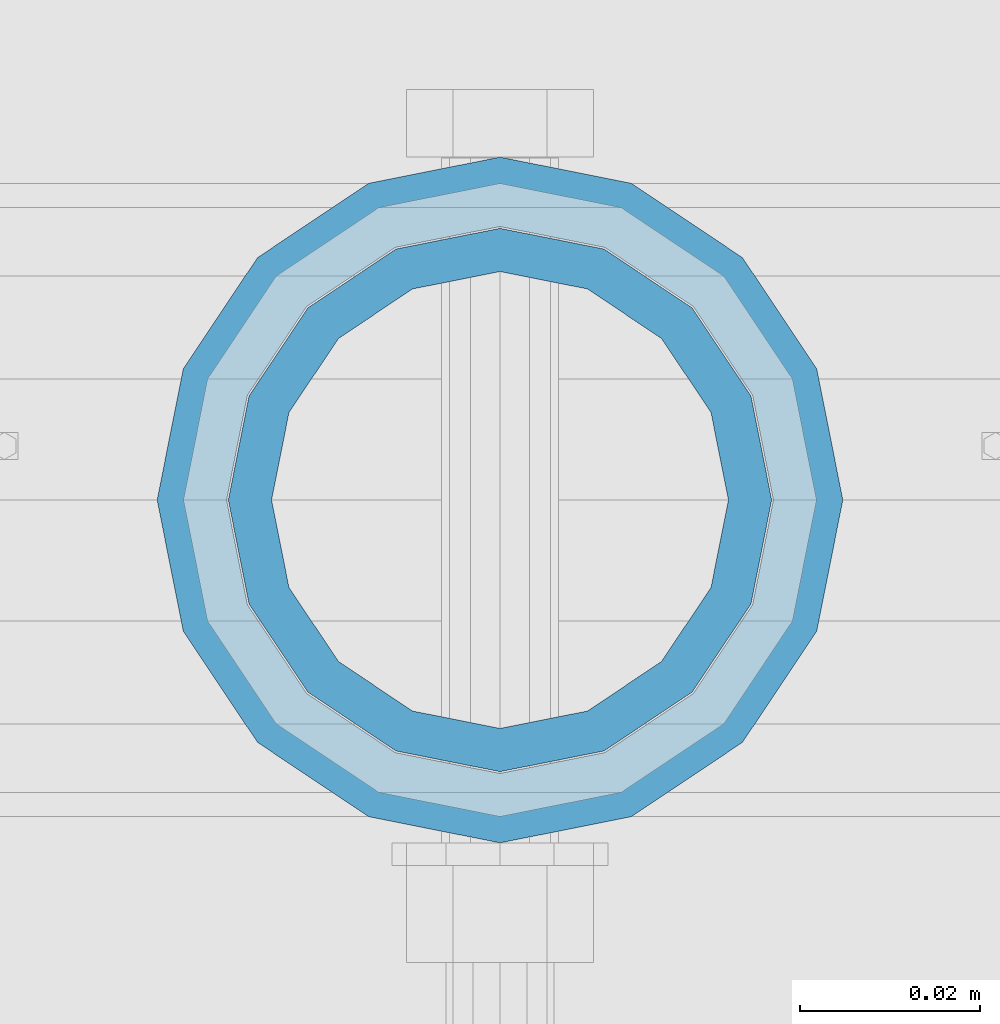
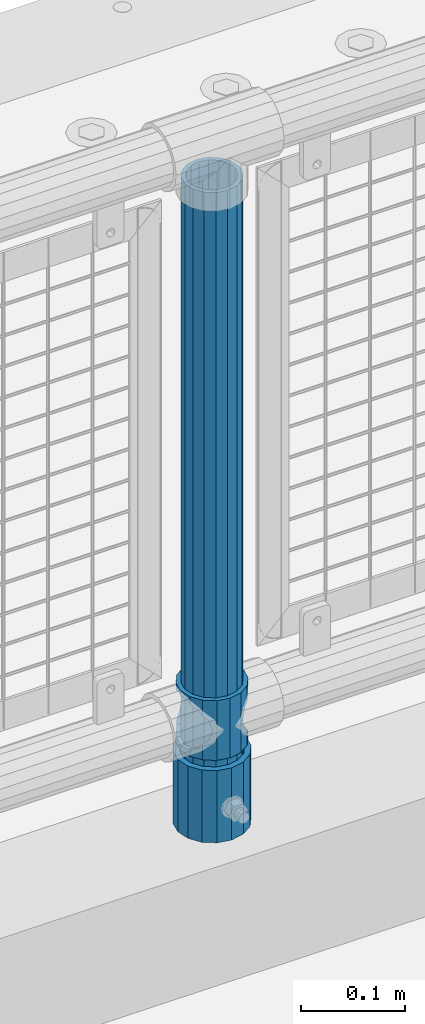
# One storey, part 71 of 247: 3 columns.
"""IFC2X3 building model written with IfcOpenShell, lengths in millimetres."""

from ifc_helpers import new_model, si_unit, frame, origin_with_axes, place, context, subcontext, project, spatial, faceted_brep, material, type_object, element, save


model = new_model("IFC2X3")

# Units and contexts
model_context = context("Model", 3, precision=1e-05, world=origin_with_axes())
body_context = subcontext(model_context, "Body", "Model", "MODEL_VIEW")
ifc_project = project(units=[si_unit("LENGTHUNIT", "METRE", prefix="MILLI"), si_unit("AREAUNIT", "SQUARE_METRE"), si_unit("VOLUMEUNIT", "CUBIC_METRE"), si_unit("MASSUNIT", "GRAM", prefix="KILO"), si_unit("TIMEUNIT", "SECOND"), si_unit("PLANEANGLEUNIT", "RADIAN"), si_unit("SOLIDANGLEUNIT", "STERADIAN"), si_unit("THERMODYNAMICTEMPERATUREUNIT", "DEGREE_CELSIUS"), si_unit("LUMINOUSINTENSITYUNIT", "LUMEN")], contexts=[model_context])

# Site, building, storey
site_placement = place(None, origin_with_axes())
site = spatial("IfcSite", under=ifc_project, at=site_placement, CompositionType="ELEMENT")
building_placement = place(site_placement, origin_with_axes())
building = spatial("IfcBuilding", under=site, at=building_placement, Name="Standard", CompositionType="ELEMENT")
storey_placement = place(building_placement, origin_with_axes())
storey = spatial("IfcBuildingStorey", under=building, at=storey_placement, Name="Undefined", CompositionType="ELEMENT", Elevation=0.0)

# Columns
ifc_material_1 = material()
column_type_1 = type_object("IfcColumnType", PredefinedType="NOTDEFINED")
column_1_placement = place(storey_placement, frame((2221.0, 7664.5, 168.02), z_axis=(0.0, 1.0, 0.0), x_axis=(0.0, 0.0, 1.0)))
element("IfcColumn", 1, at=column_1_placement, inside=storey, type_object=column_type_1, material=ifc_material_1, context=body_context, shape_type="Brep", body=[
    faceted_brep([(0.0, -31.75, 0.0), (0.0, -29.3331751572332, 12.1501989775916), (85.0, -29.3331751572332, 12.1501989775916), (85.0, -31.75, 0.0), (0.0, -22.4506403026735, 22.4506403026726), (85.0, -22.4506403026735, 22.4506403026726), (0.0, -12.1501989775916, 29.3331751572332), (85.0, -12.1501989775916, 29.3331751572332), (0.0, 0.0, 31.75), (85.0, 0.0, 31.75), (0.0, 12.1501989775916, 29.3331751572332), (85.0, 12.1501989775916, 29.3331751572332), (0.0, 22.4506403026735, 22.4506403026726), (85.0, 22.4506403026735, 22.4506403026726), (0.0, 29.3331751572332, 12.1501989775916), (85.0, 29.3331751572332, 12.1501989775916), (0.0, 31.75, 0.0), (85.0, 31.75, 0.0), (0.0, 29.3331751572332, -12.1501989775916), (85.0, 29.3331751572332, -12.1501989775916), (0.0, 22.4506403026735, -22.4506403026726), (85.0, 22.4506403026735, -22.4506403026726), (0.0, 12.1501989775916, -29.3331751572332), (85.0, 12.1501989775916, -29.3331751572332), (0.0, 0.0, -31.75), (85.0, 0.0, -31.75), (0.0, -12.1501989775916, -29.3331751572332), (85.0, -12.1501989775916, -29.3331751572332), (0.0, -22.4506403026735, -22.4506403026726), (85.0, -22.4506403026735, -22.4506403026726), (0.0, -29.3331751572332, -12.1501989775916), (85.0, -29.3331751572332, -12.1501989775916), (0.0, -38.0499999999993, 0.0), (0.0, -35.1536162120537, -14.5611046014919), (85.0, -35.1536162120537, -14.5611046014919), (85.0, -38.0499999999993, 0.0), (0.0, -26.9054130241475, -26.9054130241484), (85.0, -26.9054130241475, -26.9054130241484), (0.0, -14.561104601491, -35.1536162120547), (85.0, -14.561104601491, -35.1536162120547), (0.0, 0.0, -38.0500000000002), (85.0, 0.0, -38.0500000000002), (0.0, 14.561104601491, -35.1536162120547), (85.0, 14.561104601491, -35.1536162120547), (0.0, 26.9054130241475, -26.9054130241484), (85.0, 26.9054130241475, -26.9054130241484), (0.0, 35.1536162120537, -14.5611046014919), (85.0, 35.1536162120537, -14.5611046014919), (0.0, 38.0499999999993, 0.0), (85.0, 38.0499999999993, 0.0), (0.0, 35.1536162120537, 14.5611046014919), (85.0, 35.1536162120537, 14.5611046014919), (0.0, 26.9054130241475, 26.9054130241484), (85.0, 26.9054130241475, 26.9054130241484), (0.0, 14.561104601491, 35.1536162120547), (85.0, 14.561104601491, 35.1536162120547), (0.0, 0.0, 38.0500000000002), (85.0, 0.0, 38.0500000000002), (0.0, -14.561104601491, 35.1536162120547), (85.0, -14.561104601491, 35.1536162120547), (0.0, -26.9054130241475, 26.9054130241484), (85.0, -26.9054130241475, 26.9054130241484), (0.0, -35.1536162120537, 14.5611046014919), (85.0, -35.1536162120537, 14.5611046014919)], [[[0, 1, 2, 3]], [[1, 4, 5, 2]], [[4, 6, 7, 5]], [[6, 8, 9, 7]], [[8, 10, 11, 9]], [[10, 12, 13, 11]], [[12, 14, 15, 13]], [[14, 16, 17, 15]], [[16, 18, 19, 17]], [[18, 20, 21, 19]], [[20, 22, 23, 21]], [[22, 24, 25, 23]], [[24, 26, 27, 25]], [[26, 28, 29, 27]], [[28, 30, 31, 29]], [[30, 0, 3, 31]], [[32, 33, 34, 35]], [[33, 36, 37, 34]], [[36, 38, 39, 37]], [[38, 40, 41, 39]], [[40, 42, 43, 41]], [[42, 44, 45, 43]], [[44, 46, 47, 45]], [[46, 48, 49, 47]], [[48, 50, 51, 49]], [[50, 52, 53, 51]], [[52, 54, 55, 53]], [[54, 56, 57, 55]], [[56, 58, 59, 57]], [[58, 60, 61, 59]], [[60, 62, 63, 61]], [[62, 32, 35, 63]], [[37, 39, 41, 43, 45, 47, 49, 51, 53, 55, 57, 59, 61, 63, 35, 34], [5, 7, 9, 11, 13, 15, 17, 19, 21, 23, 25, 27, 29, 31, 3, 2]], [[62, 60, 58, 56, 54, 52, 50, 48, 46, 44, 42, 40, 38, 36, 33, 32], [30, 28, 26, 24, 22, 20, 18, 16, 14, 12, 10, 8, 6, 4, 1, 0]]]),
])
ifc_material_2 = material(Name="Misc_Undefined")
column_type_2 = type_object("IfcColumnType", PredefinedType="NOTDEFINED")
column_2_placement = place(storey_placement, frame((2221.0, 7664.5, 263.02), z_axis=(-1.0, 0.0, 0.0), x_axis=(0.0, 0.0, 1.0)))
element("IfcColumn", 2, at=column_2_placement, inside=storey, type_object=column_type_2, material=ifc_material_2, context=body_context, shape_type="Brep", body=[
    faceted_brep([(56.6106908090114, 21.4606908090118, -21.4606908090118), (56.6106908090114, 21.4606908090118, -27.1226768591096), (61.9623795176755, 13.4513226476329, -32.4743655677721), (63.1897438117172, 11.6144421722802, -32.839743811719), (63.1897438117172, 11.6144421722802, -28.0397438117179), (46.7644421722801, 28.0397438117179, -11.6144421722802), (46.7644421722801, 28.0397438117179, -20.088203122983), (51.5310424080055, 24.8548033587067, -24.8548033587067), (35.1499999999996, 30.35, 0.0), (35.1499999999996, 30.3500000000004, -16.6306603983649), (23.5355578277192, 28.0397438117179, -11.6144421722802), (23.5355578277192, 28.0397438117179, -20.088203122983), (13.6893091909879, 21.4606908090118, -21.4606908090118), (13.6893091909879, 21.4606908090118, -27.1226768591096), (18.768957591997, 24.8548033587067, -24.8548033587067), (7.11025618828211, 11.6144421722802, -28.0397438117179), (7.11025618828211, 11.6144421722802, -32.839743811719), (8.33762048232387, 13.4513226476329, -32.4743655677721), (4.79999999999961, 0.0, -30.3500000000004), (4.79999999999961, 0.0, -35.1499999999996), (7.11025618828211, -11.6144421722802, -28.0397438117179), (7.11025618828211, -11.6144421722802, -32.839743811719), (13.6893091909879, -21.4606908090118, -21.4606908090118), (13.6893091909879, -21.4606908090118, -27.1226768591077), (8.33762048232325, -13.4513226476329, -32.4743655677721), (23.5355578277191, -28.0397438117179, -11.6144421722802), (23.5355578277191, -28.0397438117179, -20.0882031229885), (18.768957591997, -24.8548033587067, -24.8548033587067), (35.1499999999996, -30.35, 0.0), (35.1499999999996, -30.3500000000004, -16.6306603983739), (46.7644421722801, -28.0397438117179, -11.6144421722802), (46.7644421722801, -28.0397438117179, -20.0882031229885), (56.6106908090114, -21.4606908090118, -21.4606908090118), (56.6106908090114, -21.4606908090118, -27.1226768591077), (51.5310424080038, -24.8548033587067, -24.8548033587067), (63.1897438117172, -11.6144421722802, -28.0397438117179), (63.1897438117172, -11.6144421722802, -32.839743811719), (61.9623795176754, -13.4513226476329, -32.4743655677721), (65.4999999999997, 0.0, -30.3500000000004), (65.4999999999997, 0.0, -35.1499999999996), (0.0, -28.0397438117179, -11.6144421722802), (0.0, -30.3500000000004, 0.0), (0.0, -21.4606908090118, -21.4606908090118), (0.0, -11.6144421722802, -28.0397438117179), (0.0, 0.0, -30.3500000000004), (0.0, 11.6144421722802, -28.0397438117179), (0.0, 21.4606908090118, -21.4606908090118), (0.0, 28.0397438117179, -11.6144421722802), (0.0, 30.3500000000004, 0.0), (0.0, 28.0397438117179, 11.6144421722802), (23.5355578277192, 28.0397438117179, 11.6144421722806), (0.0, 21.4606908090118, 21.4606908090118), (13.6893091909879, 21.4606908090118, 21.4606908090118), (0.0, 11.6144421722802, 28.0397438117179), (7.11025618828211, 11.6144421722802, 28.0397438117175), (0.0, 0.0, 30.3500000000004), (4.79999999999961, 0.0, 30.3499999999999), (0.0, -11.6144421722802, 28.0397438117179), (7.11025618828205, -11.6144421722802, 28.0397438117175), (0.0, -21.4606908090118, 21.4606908090118), (13.6893091909879, -21.4606908090118, 21.4606908090118), (0.0, -28.0397438117179, 11.6144421722802), (23.5355578277191, -28.0397438117179, 11.6144421722806), (0.0, -32.4743655677721, 13.4513226476338), (0.0, -35.1499999999996, 0.0), (70.2999999999993, -35.1499999999996, 0.0), (70.2999999999993, -32.4743655677721, 13.4513226476338), (0.0, 13.4513226476329, -32.4743655677721), (0.0, 24.8548033587067, -24.8548033587067), (0.0, 0.0, -35.1499999999996), (0.0, -13.4513226476329, -32.4743655677721), (0.0, -24.8548033587067, -24.8548033587067), (0.0, -24.8548033587067, 24.8548033587067), (0.0, -13.4513226476329, 32.4743655677721), (0.0, 0.0, 35.1499999999996), (0.0, 13.4513226476329, 32.4743655677721), (0.0, 24.8548033587067, 24.8548033587067), (0.0, 32.4743655677721, 13.4513226476338), (0.0, 35.1499999999996, 0.0), (0.0, 32.4743655677721, -13.4513226476338), (0.0, -32.4743655677721, -13.4513226476338), (70.2999999999993, 32.4743655677721, 13.4513226476338), (70.2999999999993, 35.1499999999996, 0.0), (70.2999999999993, 32.4743655677721, -13.4513226476338), (70.2999999999993, 24.8548033587067, -24.8548033587067), (70.2999999999993, 13.4513226476329, -32.4743655677721), (70.2999999999993, 0.0, -35.1499999999996), (70.2999999999993, -13.4513226476329, -32.4743655677721), (70.2999999999993, -24.8548033587067, -24.8548033587067), (70.2999999999993, -32.4743655677721, -13.4513226476338), (70.2999999999993, 28.0397438117179, 11.6144421722802), (70.2999999999993, 21.4606908090118, 21.4606908090118), (56.6106908090114, 21.4606908090118, 21.4606908090118), (46.7644421722801, 28.0397438117179, 11.6144421722806), (70.2999999999993, 11.6144421722802, 28.0397438117179), (63.1897438117172, 11.6144421722802, 28.0397438117175), (70.2999999999993, 0.0, 30.3500000000004), (65.4999999999997, 0.0, 30.3499999999999), (70.2999999999993, -11.6144421722802, 28.0397438117179), (63.1897438117172, -11.6144421722802, 28.0397438117175), (70.2999999999993, -21.4606908090118, 21.4606908090118), (56.6106908090114, -21.4606908090118, 21.4606908090118), (70.2999999999993, -28.0397438117179, 11.6144421722802), (46.7644421722801, -28.0397438117179, 11.6144421722806), (70.2999999999993, -11.6144421722802, -28.0397438117179), (70.2999999999993, 0.0, -30.3500000000004), (70.2999999999993, -21.4606908090118, -21.4606908090118), (70.2999999999993, -28.0397438117179, -11.6144421722802), (70.2999999999993, -30.3500000000004, 0.0), (70.2999999999993, 24.8548033587067, 24.8548033587067), (70.2999999999993, 13.4513226476329, 32.4743655677721), (70.2999999999993, 0.0, 35.1499999999996), (70.2999999999993, -13.4513226476329, 32.4743655677721), (70.2999999999993, -24.8548033587067, 24.8548033587067), (70.2999999999993, 30.3500000000004, 0.0), (70.2999999999993, 28.0397438117179, -11.6144421722802), (70.2999999999993, 21.4606908090118, -21.4606908090118), (70.2999999999993, 11.6144421722802, -28.0397438117179), (61.9623795176755, 13.4513226476329, 32.4743655677717), (51.5310424080043, 24.8548033587067, 24.8548033587072), (56.6106908090114, 21.4606908090118, 27.1226768591082), (65.4999999999997, 0.0, 35.1500000000001), (63.1897438117172, 11.6144421722802, 32.8397438117177), (63.1897438117172, -11.6144421722802, 32.8397438117177), (61.962379517675, -13.4513226476329, 32.4743655677717), (56.6106908090114, -21.4606908090118, 27.1226768591068), (51.5310424080026, -24.8548033587067, 24.8548033587072), (18.7689575919956, -24.8548033587067, 24.8548033587072), (46.7644421722801, -28.0397438117179, 20.088203122983), (35.1499999999996, -30.3500000000004, 16.6306603983649), (23.5355578277191, -28.0397438117179, 20.088203122983), (8.33762048232268, -13.4513226476329, 32.4743655677717), (13.6893091909879, -21.4606908090118, 27.1226768591068), (4.79999999999961, 0.0, 35.1500000000001), (7.11025618828205, -11.6144421722802, 32.8397438117177), (7.11025618828211, 11.6144421722802, 32.8397438117177), (8.33762048232427, 13.4513226476329, 32.4743655677717), (13.6893091909879, 21.4606908090118, 27.1226768591082), (18.7689575919966, 24.8548033587067, 24.8548033587072), (23.5355578277192, 28.0397438117179, 20.0882031229844), (35.1499999999996, 30.3500000000004, 16.6306603983667), (46.7644421722801, 28.0397438117179, 20.0882031229844)], [[[0, 1, 2, 3, 4]], [[5, 6, 7, 1, 0]], [[8, 9, 6, 5]], [[10, 11, 9, 8]], [[12, 13, 14, 11, 10]], [[15, 16, 17, 13, 12]], [[18, 19, 16, 15]], [[20, 21, 19, 18]], [[22, 23, 24, 21, 20]], [[25, 26, 27, 23, 22]], [[28, 29, 26, 25]], [[30, 31, 29, 28]], [[32, 33, 34, 31, 30]], [[35, 36, 37, 33, 32]], [[38, 39, 36, 35]], [[4, 3, 39, 38]], [[40, 41, 28, 25]], [[42, 40, 25, 22]], [[43, 42, 22, 20]], [[44, 43, 20, 18]], [[45, 44, 18, 15]], [[46, 45, 15, 12]], [[47, 46, 12, 10]], [[48, 47, 10, 8]], [[49, 48, 8, 50]], [[51, 49, 50, 52]], [[53, 51, 52, 54]], [[55, 53, 54, 56]], [[57, 55, 56, 58]], [[59, 57, 58, 60]], [[61, 59, 60, 62]], [[41, 61, 62, 28]], [[63, 64, 65, 66]], [[17, 67, 68, 14, 13]], [[19, 69, 67, 17, 16]], [[70, 69, 19, 21, 24]], [[71, 70, 24, 23, 27]], [[63, 72, 73, 74, 75, 76, 77, 78, 79, 68, 67, 69, 70, 71, 80, 64], [40, 42, 43, 44, 45, 46, 47, 48, 49, 51, 53, 55, 57, 59, 61, 41]], [[78, 77, 81, 82]], [[79, 78, 82, 83]], [[14, 68, 79, 83, 84, 7, 6, 9, 11]], [[84, 85, 2, 1, 7]], [[85, 86, 39, 3, 2]], [[37, 87, 88, 34, 33]], [[39, 86, 87, 37, 36]], [[34, 88, 89, 80, 71, 27, 26, 29, 31]], [[64, 80, 89, 65]], [[90, 91, 92, 93]], [[91, 94, 95, 92]], [[94, 96, 97, 95]], [[96, 98, 99, 97]], [[98, 100, 101, 99]], [[100, 102, 103, 101]], [[104, 105, 38, 35]], [[106, 104, 35, 32]], [[107, 106, 32, 30]], [[108, 107, 30, 28]], [[102, 108, 28, 103]], [[88, 87, 86, 85, 84, 83, 82, 81, 109, 110, 111, 112, 113, 66, 65, 89], [100, 98, 96, 94, 91, 90, 114, 115, 116, 117, 105, 104, 106, 107, 108, 102]], [[118, 110, 109, 119, 120]], [[121, 111, 110, 118, 122]], [[112, 111, 121, 123, 124]], [[113, 112, 124, 125, 126]], [[127, 72, 63, 66, 113, 126, 128, 129, 130]], [[131, 73, 72, 127, 132]], [[133, 74, 73, 131, 134]], [[75, 74, 133, 135, 136]], [[76, 75, 136, 137, 138]], [[119, 109, 81, 77, 76, 138, 139, 140, 141]], [[92, 120, 119, 141, 93]], [[95, 122, 118, 120, 92]], [[97, 121, 122, 95]], [[99, 123, 121, 97]], [[101, 125, 124, 123, 99]], [[103, 128, 126, 125, 101]], [[28, 129, 128, 103]], [[62, 130, 129, 28]], [[60, 132, 127, 130, 62]], [[58, 134, 131, 132, 60]], [[56, 133, 134, 58]], [[54, 135, 133, 56]], [[52, 137, 136, 135, 54]], [[50, 139, 138, 137, 52]], [[8, 140, 139, 50]], [[93, 141, 140, 8]], [[114, 90, 93, 8]], [[115, 114, 8, 5]], [[116, 115, 5, 0]], [[117, 116, 0, 4]], [[105, 117, 4, 38]]]),
])
column_type_3 = type_object("IfcColumnType", PredefinedType="NOTDEFINED")
column_3_placement = place(storey_placement, frame((2221.0, 7664.5, 168.02), z_axis=(-1.0, 0.0, 0.0), x_axis=(0.0, 0.0, 1.0)))
element("IfcColumn", 3, at=column_3_placement, inside=storey, type_object=column_type_3, material=ifc_material_1, context=body_context, shape_type="Brep", body=[
    faceted_brep([(0.0, -25.3500000000004, 0.0), (0.0, -23.4203461491616, 9.70102501045585), (760.0, -23.4203461491616, 9.70102501045585), (760.0, -25.3500000000004, 0.0), (0.0, -17.9251569030794, 17.9251569030785), (760.0, -17.9251569030794, 17.9251569030785), (0.0, -9.70102501045494, 23.4203461491616), (760.0, -9.70102501045494, 23.4203461491616), (0.0, 0.0, 25.3500000000004), (760.0, 0.0, 25.3500000000004), (0.0, 9.70102501045494, 23.4203461491616), (760.0, 9.70102501045494, 23.4203461491616), (0.0, 17.9251569030794, 17.9251569030785), (760.0, 17.9251569030794, 17.9251569030785), (0.0, 23.4203461491616, 9.70102501045585), (760.0, 23.4203461491616, 9.70102501045585), (0.0, 25.3500000000004, 0.0), (760.0, 25.3500000000004, 0.0), (0.0, 23.4203461491616, -9.70102501045585), (760.0, 23.4203461491616, -9.70102501045585), (0.0, 17.9251569030794, -17.9251569030785), (760.0, 17.9251569030794, -17.9251569030785), (0.0, 9.70102501045494, -23.4203461491616), (760.0, 9.70102501045494, -23.4203461491616), (0.0, 0.0, -25.3500000000004), (760.0, 0.0, -25.3500000000004), (0.0, -9.70102501045494, -23.4203461491616), (760.0, -9.70102501045494, -23.4203461491616), (0.0, -17.9251569030794, -17.9251569030785), (760.0, -17.9251569030794, -17.9251569030785), (0.0, -23.4203461491616, -9.70102501045585), (760.0, -23.4203461491616, -9.70102501045585), (0.0, -30.1499999999996, 0.0), (0.0, -27.8549679052148, -11.5379054858076), (760.0, -27.8549679052148, -11.5379054858076), (760.0, -30.1499999999996, 0.0), (0.0, -21.3192694527743, -21.3192694527752), (760.0, -21.3192694527743, -21.3192694527752), (0.0, -11.5379054858076, -27.8549679052157), (760.0, -11.5379054858076, -27.8549679052157), (0.0, 0.0, -30.1499999999996), (760.0, 0.0, -30.1499999999996), (0.0, 11.5379054858076, -27.8549679052157), (760.0, 11.5379054858076, -27.8549679052157), (0.0, 21.3192694527743, -21.3192694527752), (760.0, 21.3192694527743, -21.3192694527752), (0.0, 27.8549679052157, -11.5379054858076), (760.0, 27.8549679052157, -11.5379054858076), (0.0, 30.1499999999996, 0.0), (760.0, 30.1499999999996, 0.0), (0.0, 27.8549679052157, 11.5379054858076), (760.0, 27.8549679052157, 11.5379054858076), (0.0, 21.3192694527743, 21.3192694527752), (760.0, 21.3192694527743, 21.3192694527752), (0.0, 11.5379054858076, 27.8549679052157), (760.0, 11.5379054858076, 27.8549679052157), (0.0, 0.0, 30.1499999999996), (760.0, 0.0, 30.1499999999996), (0.0, -11.5379054858076, 27.8549679052157), (760.0, -11.5379054858076, 27.8549679052157), (0.0, -21.3192694527743, 21.3192694527752), (760.0, -21.3192694527743, 21.3192694527752), (0.0, -27.8549679052157, 11.5379054858076), (760.0, -27.8549679052157, 11.5379054858076)], [[[0, 1, 2, 3]], [[1, 4, 5, 2]], [[4, 6, 7, 5]], [[6, 8, 9, 7]], [[8, 10, 11, 9]], [[10, 12, 13, 11]], [[12, 14, 15, 13]], [[14, 16, 17, 15]], [[16, 18, 19, 17]], [[18, 20, 21, 19]], [[20, 22, 23, 21]], [[22, 24, 25, 23]], [[24, 26, 27, 25]], [[26, 28, 29, 27]], [[28, 30, 31, 29]], [[30, 0, 3, 31]], [[32, 33, 34, 35]], [[33, 36, 37, 34]], [[36, 38, 39, 37]], [[38, 40, 41, 39]], [[40, 42, 43, 41]], [[42, 44, 45, 43]], [[44, 46, 47, 45]], [[46, 48, 49, 47]], [[48, 50, 51, 49]], [[50, 52, 53, 51]], [[52, 54, 55, 53]], [[54, 56, 57, 55]], [[56, 58, 59, 57]], [[58, 60, 61, 59]], [[60, 62, 63, 61]], [[62, 32, 35, 63]], [[37, 39, 41, 43, 45, 47, 49, 51, 53, 55, 57, 59, 61, 63, 35, 34], [5, 7, 9, 11, 13, 15, 17, 19, 21, 23, 25, 27, 29, 31, 3, 2]], [[62, 60, 58, 56, 54, 52, 50, 48, 46, 44, 42, 40, 38, 36, 33, 32], [30, 28, 26, 24, 22, 20, 18, 16, 14, 12, 10, 8, 6, 4, 1, 0]]]),
])

save(model, "model.ifc")
